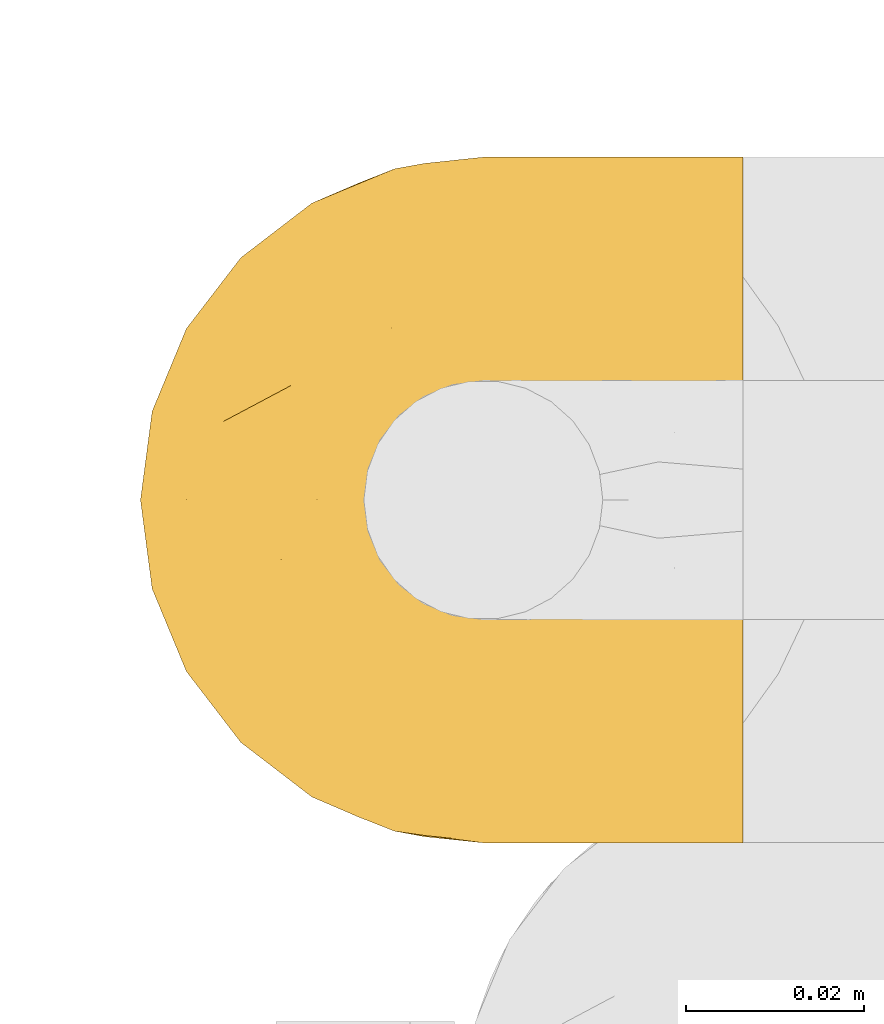
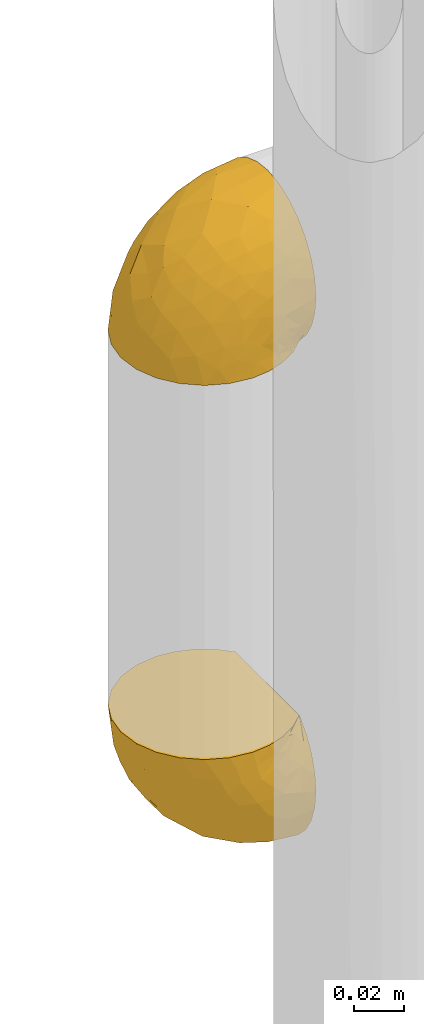
# One storey, part 114 of 827: 2 coverings.
"""IFC2X3 building model written with IfcOpenShell, lengths in millimetres."""

from ifc_helpers import new_model, entity, si_unit, converted_unit, derived_unit, direction, frame, origin, place, context, subcontext, project, spatial, faceted_brep, element, save


model = new_model("IFC2X3")

# Units and contexts
model_context = context("Model", 3, precision=0.01, world=origin(), true_north=direction((6.12303176911189e-17, 1.0)))
body_context = subcontext(model_context, "Body", "Model", "MODEL_VIEW")
ifc_project = project(units=[si_unit("LENGTHUNIT", "METRE", prefix="MILLI"), si_unit("AREAUNIT", "SQUARE_METRE"), si_unit("VOLUMEUNIT", "CUBIC_METRE"), converted_unit("PLANEANGLEUNIT", "DEGREE", entity("IfcRatioMeasure", 0.0174532925199433), si_unit("PLANEANGLEUNIT", "RADIAN"), dimensions=[0, 0, 0, 0, 0, 0, 0]), si_unit("MASSUNIT", "GRAM", prefix="KILO"), derived_unit("MASSDENSITYUNIT", [(si_unit("MASSUNIT", "GRAM", prefix="KILO"), 1), (si_unit("LENGTHUNIT", "METRE"), -3)]), derived_unit("MOMENTOFINERTIAUNIT", [(si_unit("LENGTHUNIT", "METRE"), 4)]), si_unit("TIMEUNIT", "SECOND"), si_unit("FREQUENCYUNIT", "HERTZ"), si_unit("THERMODYNAMICTEMPERATUREUNIT", "DEGREE_CELSIUS"), derived_unit("THERMALTRANSMITTANCEUNIT", [(si_unit("MASSUNIT", "GRAM", prefix="KILO"), 1), (si_unit("THERMODYNAMICTEMPERATUREUNIT", "KELVIN"), -1), (si_unit("TIMEUNIT", "SECOND"), -3)]), derived_unit("VOLUMETRICFLOWRATEUNIT", [(si_unit("LENGTHUNIT", "METRE"), 3), (si_unit("TIMEUNIT", "SECOND"), -1)]), derived_unit("MASSFLOWRATEUNIT", [(si_unit("MASSUNIT", "GRAM", prefix="KILO"), 1), (si_unit("TIMEUNIT", "SECOND"), -1)]), derived_unit("ROTATIONALFREQUENCYUNIT", [(si_unit("TIMEUNIT", "SECOND"), -1)]), si_unit("ELECTRICCURRENTUNIT", "AMPERE"), si_unit("ELECTRICVOLTAGEUNIT", "VOLT"), si_unit("POWERUNIT", "WATT"), si_unit("FORCEUNIT", "NEWTON", prefix="KILO"), si_unit("ILLUMINANCEUNIT", "LUX"), si_unit("LUMINOUSFLUXUNIT", "LUMEN"), si_unit("LUMINOUSINTENSITYUNIT", "CANDELA"), derived_unit("USERDEFINED", [(si_unit("MASSUNIT", "GRAM", prefix="KILO"), -1), (si_unit("LENGTHUNIT", "METRE"), -2), (si_unit("TIMEUNIT", "SECOND"), 3), (si_unit("LUMINOUSFLUXUNIT", "LUMEN"), 1)]), derived_unit("LINEARVELOCITYUNIT", [(si_unit("LENGTHUNIT", "METRE"), 1), (si_unit("TIMEUNIT", "SECOND"), -1)]), si_unit("PRESSUREUNIT", "PASCAL"), derived_unit("USERDEFINED", [(si_unit("LENGTHUNIT", "METRE"), -2), (si_unit("MASSUNIT", "GRAM", prefix="KILO"), 1), (si_unit("TIMEUNIT", "SECOND"), -2)]), derived_unit("LINEARFORCEUNIT", [(si_unit("MASSUNIT", "GRAM", prefix="KILO"), 1), (si_unit("LENGTHUNIT", "METRE"), 1), (si_unit("TIMEUNIT", "SECOND"), -2), (si_unit("LENGTHUNIT", "METRE"), -1)]), derived_unit("PLANARFORCEUNIT", [(si_unit("MASSUNIT", "GRAM", prefix="KILO"), 1), (si_unit("LENGTHUNIT", "METRE"), 1), (si_unit("TIMEUNIT", "SECOND"), -2), (si_unit("LENGTHUNIT", "METRE"), -2)])], contexts=[model_context])

# Site, building, storey
site_placement = place(None, origin())
site = spatial("IfcSite", under=ifc_project, at=site_placement, CompositionType="ELEMENT")
building_placement = place(site_placement, origin())
building = spatial("IfcBuilding", under=site, at=building_placement, CompositionType="ELEMENT")
storey_placement = place(building_placement, frame((0.0, 0.0, 28200.0)))
storey = spatial("IfcBuildingStorey", under=building, at=storey_placement, Name="08", CompositionType="ELEMENT", Elevation=28200.0)

# Coverings
covering_1_placement = place(storey_placement, frame((22641.02, 11905.95, 1018.27)))
element("IfcCovering", 1, at=covering_1_placement, inside=storey, Name=":ADSK_", ObjectType=":ADSK_", PredefinedType="INSULATION", context=body_context, shape_type="Brep", body=[
    faceted_brep([(69.15, 5.41, 23.36), (69.15, 9.99, 16.07), (69.15, 16.08, 9.98), (69.15, 23.37, 5.4), (69.15, 31.49, 2.56), (69.15, 40.05, 1.6), (69.15, 48.61, 2.56), (69.15, 56.73, 5.41), (69.15, 64.02, 9.99), (69.15, 70.11, 16.08), (69.15, 74.69, 23.37), (69.15, 77.53, 31.49), (69.15, 78.5, 40.05), (69.15, 77.63, 48.15), (69.15, 75.08, 55.88), (69.15, 70.97, 62.9), (69.15, 65.47, 68.89), (69.15, 63.27, 68.89), (69.15, 61.53, 68.89), (69.15, 59.57, 68.89), (69.15, 57.6, 68.89), (69.15, 55.63, 68.89), (69.15, 53.67, 68.89), (69.15, 51.7, 68.89), (69.15, 49.73, 68.89), (69.15, 47.54, 68.89), (69.15, 45.34, 68.89), (69.15, 43.15, 68.89), (69.15, 40.96, 68.89), (69.15, 38.76, 68.89), (69.15, 36.57, 68.89), (69.15, 34.37, 68.89), (69.15, 32.18, 68.89), (69.15, 29.98, 68.89), (69.15, 27.79, 68.89), (69.15, 25.6, 68.89), (69.15, 23.4, 68.89), (69.15, 21.21, 68.89), (69.15, 19.01, 68.89), (69.15, 16.82, 68.89), (69.15, 14.62, 68.89), (69.15, 9.12, 62.89), (69.15, 5.0, 55.86), (69.15, 2.46, 48.13), (69.15, 1.6, 40.05), (69.15, 2.56, 31.49), (68.89, 65.47, 69.15), (62.89, 70.97, 69.15), (55.87, 75.09, 69.15), (48.14, 77.63, 69.15), (40.05, 78.5, 69.15), (30.09, 77.19, 69.15), (20.82, 73.34, 69.15), (12.86, 67.23, 69.15), (6.75, 59.27, 69.15), (2.91, 50.0, 69.15), (1.6, 40.05, 69.15), (2.91, 30.09, 69.15), (6.75, 20.82, 69.15), (12.86, 12.86, 69.15), (20.82, 6.75, 69.15), (30.09, 2.91, 69.15), (40.05, 1.6, 69.15), (48.14, 2.46, 69.15), (55.87, 5.0, 69.15), (62.89, 9.12, 69.15), (68.89, 14.62, 69.15), (68.89, 16.82, 69.15), (68.89, 17.8, 69.15), (68.89, 19.39, 69.15), (68.89, 20.98, 69.15), (68.89, 22.57, 69.15), (68.89, 24.16, 69.15), (68.89, 25.75, 69.15), (68.89, 27.33, 69.15), (68.89, 28.92, 69.15), (68.89, 30.51, 69.15), (68.89, 32.1, 69.15), (68.89, 33.69, 69.15), (68.89, 35.28, 69.15), (68.89, 36.87, 69.15), (68.89, 38.46, 69.15), (68.89, 40.05, 69.15), (68.89, 41.63, 69.15), (68.89, 43.22, 69.15), (68.89, 44.81, 69.15), (68.89, 46.4, 69.15), (68.89, 47.99, 69.15), (68.89, 49.58, 69.15), (68.89, 51.17, 69.15), (68.89, 52.76, 69.15), (68.89, 54.72, 69.15), (68.89, 56.69, 69.15), (68.89, 58.88, 69.15), (68.89, 61.08, 69.15), (68.89, 63.27, 69.15), (68.97, 37.77, 68.96), (68.96, 36.07, 68.97), (68.97, 32.96, 68.97), (68.97, 31.36, 68.97), (68.98, 56.52, 68.95), (68.97, 54.96, 68.96), (68.96, 18.75, 68.98), (68.96, 58.07, 68.97), (68.96, 50.37, 68.97), (68.96, 23.36, 68.98), (68.96, 24.95, 68.97), (68.96, 42.43, 68.97), (69.0, 15.97, 68.94), (68.96, 51.96, 68.98), (68.96, 53.47, 68.98), (68.97, 48.63, 68.96), (68.96, 63.93, 68.97), (68.96, 40.93, 68.98), (68.96, 29.72, 68.98), (68.97, 62.4, 68.97), (68.97, 60.92, 68.96), (68.97, 17.31, 68.97), (68.96, 21.74, 68.97), (68.96, 34.56, 68.98), (68.97, 20.18, 68.96), (68.97, 14.62, 68.97), (69.02, 14.62, 68.94), (69.08, 14.62, 68.92), (68.97, 65.47, 68.97), (68.94, 65.47, 69.02), (68.92, 65.47, 69.08), (68.96, 59.5, 68.98), (68.96, 47.1, 68.97), (68.95, 45.61, 68.98), (68.96, 28.18, 68.97), (68.92, 14.62, 69.08), (68.94, 14.62, 69.02), (68.98, 26.61, 68.96), (69.08, 65.47, 68.92), (69.02, 65.47, 68.94), (68.96, 39.32, 68.97), (68.97, 44.12, 68.96), (61.33, 72.26, 67.02), (53.1, 76.57, 63.33), (63.33, 71.77, 64.61), (55.53, 77.9, 51.4), (63.33, 76.56, 53.1), (54.6, 78.5, 43.94), (41.99, 78.5, 61.87), (57.07, 75.52, 61.54), (57.95, 76.13, 57.95), (51.56, 77.81, 56.12), (41.58, 78.5, 63.4), (61.7, 72.4, 65.41), (65.0, 71.77, 63.04), (67.02, 72.25, 61.33), (61.87, 78.5, 41.99), (49.27, 78.5, 49.27), (43.94, 78.5, 54.6), (61.21, 75.75, 56.6), (63.4, 78.5, 41.58), (33.11, 50.46, 13.72), (52.82, 52.75, 5.82), (43.3, 40.05, 6.74), (33.73, 77.7, 58.82), (36.52, 77.66, 51.58), (24.87, 71.02, 42.09), (14.17, 63.45, 46.12), (18.43, 70.55, 55.56), (28.67, 75.57, 52.38), (26.0, 75.57, 61.54), (49.25, 72.61, 23.76), (59.72, 72.61, 20.5), (55.1, 67.24, 14.64), (44.72, 77.74, 41.77), (34.15, 57.43, 16.28), (5.25, 47.19, 49.4), (6.75, 54.76, 52.34), (55.54, 40.05, 4.3), (10.47, 63.45, 58.67), (25.49, 60.1, 25.26), (35.53, 63.72, 20.17), (48.22, 76.83, 34.7), (58.71, 76.34, 28.67), (57.42, 60.51, 8.62), (34.84, 72.59, 33.37), (36.87, 76.05, 41.35), (45.01, 66.15, 17.15), (44.4, 60.51, 12.68), (23.96, 51.88, 21.47), (11.2, 55.34, 41.11), (10.56, 48.67, 37.53), (16.81, 53.89, 30.64), (17.38, 46.73, 26.66), (21.38, 40.05, 21.38), (32.34, 40.05, 14.06), (4.3, 40.05, 55.54), (20.65, 63.95, 35.17), (29.66, 67.24, 29.04), (39.6, 69.62, 24.34), (42.55, 73.6, 29.33), (6.74, 40.05, 43.3), (14.06, 40.05, 32.34), (26.84, 4.52, 57.75), (5.28, 32.72, 49.41), (18.52, 27.18, 27.85), (33.13, 29.63, 13.7), (55.1, 12.86, 14.63), (57.43, 19.59, 8.61), (20.72, 9.54, 48.85), (11.46, 16.64, 54.13), (17.69, 17.48, 37.84), (49.26, 7.49, 23.75), (59.73, 7.49, 20.49), (58.71, 3.75, 28.66), (29.72, 20.75, 20.83), (35.35, 2.33, 55.15), (43.94, 1.6, 54.6), (41.99, 1.6, 61.87), (63.4, 1.6, 41.58), (4.93, 26.94, 57.58), (17.46, 9.54, 59.91), (10.94, 31.21, 36.94), (8.92, 25.33, 45.72), (52.83, 27.35, 5.82), (29.34, 8.17, 37.91), (30.26, 4.3, 50.18), (44.4, 19.59, 12.67), (39.06, 2.23, 49.29), (43.06, 2.45, 42.64), (54.6, 1.6, 43.94), (49.27, 1.6, 49.27), (42.69, 12.86, 19.45), (48.2, 3.27, 34.7), (61.87, 1.6, 41.99), (33.44, 2.29, 62.29), (29.67, 12.86, 29.01), (38.5, 6.89, 31.47), (23.35, 12.43, 37.18), (34.97, 4.1, 43.45), (53.1, 3.53, 63.33), (59.68, 6.88, 67.23), (62.19, 8.16, 66.07), (64.11, 9.02, 65.22), (57.97, 5.0, 61.99), (57.95, 3.96, 57.95), (63.33, 3.52, 53.09), (51.77, 2.4, 56.84), (67.02, 7.83, 61.33), (64.98, 8.32, 63.06), (55.53, 2.19, 51.41), (61.22, 4.34, 56.61)], [[[0, 1, 2, 3, 4, 5, 6, 7, 8, 9, 10, 11, 12, 13, 14, 15, 16, 17, 18, 19, 20, 21, 22, 23, 24, 25, 26, 27, 28, 29, 30, 31, 32, 33, 34, 35, 36, 37, 38, 39, 40, 41, 42, 43, 44, 45]], [[46, 47, 48, 49, 50, 51, 52, 53, 54, 55, 56, 57, 58, 59, 60, 61, 62, 63, 64, 65, 66, 67, 68, 69, 70, 71, 72, 73, 74, 75, 76, 77, 78, 79, 80, 81, 82, 83, 84, 85, 86, 87, 88, 89, 90, 91, 92, 93, 94, 95]], [[96, 97, 30]], [[98, 77, 99]], [[100, 101, 21]], [[69, 68, 102]], [[20, 19, 103]], [[24, 23, 104]], [[20, 103, 100]], [[72, 105, 106]], [[84, 83, 107]], [[89, 88, 104]], [[108, 67, 66]], [[109, 110, 90]], [[111, 25, 24]], [[112, 17, 16]], [[82, 113, 83]], [[109, 23, 22]], [[114, 76, 75]], [[105, 36, 106]], [[104, 111, 24]], [[18, 115, 116]], [[97, 96, 80]], [[67, 108, 117]], [[105, 71, 118]], [[31, 97, 119]], [[102, 120, 69]], [[108, 121, 122, 123, 40]], [[112, 95, 115]], [[17, 115, 18]], [[94, 116, 115]], [[117, 68, 67]], [[38, 117, 39]], [[112, 124, 125, 126, 46]], [[17, 112, 115]], [[70, 120, 118]], [[39, 117, 108]], [[120, 38, 37]], [[120, 37, 118]], [[120, 70, 69]], [[116, 94, 127]], [[128, 86, 129]], [[117, 38, 102]], [[74, 130, 75]], [[99, 33, 32]], [[115, 95, 94]], [[39, 108, 40]], [[108, 66, 131, 132, 121]], [[105, 72, 71]], [[118, 37, 36]], [[71, 70, 118]], [[35, 106, 36]], [[36, 105, 118]], [[35, 133, 106]], [[74, 73, 133]], [[106, 133, 73]], [[99, 114, 33]], [[133, 35, 34]], [[73, 72, 106]], [[95, 112, 46]], [[112, 16, 134, 135, 124]], [[130, 114, 75]], [[99, 76, 114]], [[114, 130, 33]], [[34, 33, 130]], [[78, 77, 98]], [[98, 119, 78]], [[130, 133, 34]], [[133, 130, 74]], [[79, 97, 80]], [[98, 99, 32]], [[98, 32, 31]], [[77, 76, 99]], [[97, 79, 119]], [[136, 96, 29]], [[30, 97, 31]], [[136, 29, 28]], [[81, 80, 96]], [[29, 96, 30]], [[31, 119, 98]], [[119, 79, 78]], [[96, 136, 81]], [[82, 81, 136]], [[113, 107, 83]], [[84, 107, 137]], [[107, 27, 137]], [[113, 28, 107]], [[27, 107, 28]], [[85, 84, 137]], [[137, 27, 26]], [[113, 136, 28]], [[136, 113, 82]], [[109, 89, 104]], [[86, 85, 129]], [[89, 109, 90]], [[111, 87, 128]], [[26, 129, 137]], [[88, 111, 104]], [[25, 111, 128]], [[22, 110, 109]], [[23, 109, 104]], [[110, 91, 90]], [[100, 92, 101]], [[110, 22, 101]], [[91, 110, 101]], [[116, 19, 18]], [[111, 88, 87]], [[127, 103, 19]], [[25, 128, 26]], [[86, 128, 87]], [[128, 129, 26]], [[137, 129, 85]], [[120, 102, 38]], [[117, 102, 68]], [[91, 101, 92]], [[21, 101, 22]], [[93, 92, 103]], [[100, 21, 20]], [[100, 103, 92]], [[127, 93, 103]], [[93, 127, 94]], [[116, 127, 19]], [[126, 138, 47]], [[48, 138, 139]], [[140, 125, 124]], [[141, 142, 143]], [[144, 49, 139]], [[145, 140, 146]], [[48, 139, 49]], [[139, 145, 147]], [[49, 144, 148, 50]], [[126, 125, 149]], [[14, 13, 142]], [[150, 146, 140]], [[149, 140, 145]], [[151, 150, 135]], [[151, 14, 142]], [[16, 15, 134]], [[13, 152, 142]], [[124, 150, 140]], [[141, 143, 153]], [[14, 151, 15]], [[15, 151, 134]], [[47, 46, 126]], [[139, 154, 144]], [[138, 48, 47]], [[125, 140, 149]], [[135, 134, 151]], [[146, 155, 141]], [[145, 146, 147]], [[149, 139, 138]], [[147, 153, 154]], [[147, 146, 141]], [[139, 147, 154]], [[139, 149, 145]], [[149, 138, 126]], [[147, 141, 153]], [[146, 150, 155]], [[151, 155, 150]], [[142, 141, 155]], [[13, 12, 156, 152]], [[152, 143, 142]], [[151, 142, 155]], [[150, 124, 135]], [[157, 158, 159]], [[160, 154, 161]], [[162, 163, 164]], [[165, 166, 160]], [[167, 168, 169]], [[153, 170, 161]], [[156, 12, 11]], [[158, 157, 171]], [[172, 55, 173]], [[158, 6, 174]], [[175, 54, 53]], [[52, 166, 164]], [[52, 164, 53]], [[54, 175, 173]], [[166, 52, 51]], [[176, 177, 171]], [[178, 143, 179]], [[156, 11, 179]], [[8, 7, 180]], [[169, 9, 8]], [[179, 143, 152, 156]], [[179, 11, 10]], [[168, 179, 10]], [[181, 162, 182]], [[179, 167, 178]], [[183, 184, 177]], [[183, 169, 184]], [[176, 171, 185]], [[172, 186, 187]], [[158, 7, 6]], [[159, 158, 174]], [[184, 180, 158]], [[54, 173, 55]], [[180, 169, 8]], [[188, 189, 187]], [[9, 168, 10]], [[186, 188, 187]], [[190, 157, 159, 191]], [[55, 172, 192]], [[176, 193, 194]], [[161, 170, 182]], [[162, 164, 165]], [[175, 164, 163]], [[51, 50, 148]], [[167, 195, 196]], [[178, 182, 170]], [[6, 5, 174]], [[158, 180, 7]], [[169, 180, 184]], [[169, 168, 9]], [[179, 168, 167]], [[182, 162, 165]], [[162, 194, 193]], [[161, 165, 160]], [[195, 181, 196]], [[192, 172, 197]], [[192, 56, 55]], [[189, 190, 198]], [[198, 197, 187]], [[172, 187, 197]], [[185, 189, 188]], [[198, 187, 189]], [[186, 172, 173]], [[173, 163, 186]], [[193, 186, 163]], [[176, 185, 188]], [[185, 157, 190]], [[188, 186, 193]], [[177, 176, 194]], [[188, 193, 176]], [[162, 193, 163]], [[195, 177, 194]], [[171, 177, 184]], [[181, 195, 194]], [[183, 167, 169]], [[162, 181, 194]], [[196, 182, 178]], [[158, 171, 184]], [[171, 157, 185]], [[177, 195, 183]], [[167, 183, 195]], [[182, 196, 181]], [[178, 170, 143]], [[178, 167, 196]], [[164, 175, 53]], [[173, 175, 163]], [[160, 51, 148]], [[164, 166, 165]], [[51, 160, 166]], [[160, 148, 144, 154]], [[153, 161, 154]], [[182, 165, 161]], [[190, 189, 185]], [[143, 170, 153]], [[60, 199, 61]], [[197, 200, 192]], [[201, 190, 202]], [[200, 57, 192]], [[203, 204, 2]], [[205, 206, 207]], [[208, 209, 210]], [[211, 207, 201]], [[212, 213, 214]], [[45, 215, 210]], [[216, 206, 58]], [[45, 44, 215]], [[59, 217, 60]], [[60, 217, 199]], [[0, 45, 210]], [[218, 201, 219]], [[202, 159, 220]], [[205, 221, 222]], [[223, 204, 203]], [[1, 203, 2]], [[57, 200, 216]], [[220, 3, 204]], [[220, 174, 4]], [[1, 0, 209]], [[212, 224, 213]], [[225, 226, 227]], [[228, 223, 203]], [[208, 210, 229]], [[210, 226, 229]], [[3, 220, 4]], [[58, 206, 59]], [[209, 203, 1]], [[202, 220, 223]], [[228, 203, 208]], [[202, 211, 201]], [[3, 2, 204]], [[202, 190, 191, 159]], [[210, 215, 230, 226]], [[199, 212, 231]], [[232, 233, 221]], [[233, 208, 229]], [[207, 206, 219]], [[217, 206, 205]], [[227, 224, 225]], [[233, 232, 228]], [[201, 207, 219]], [[234, 232, 221]], [[218, 219, 200]], [[202, 223, 211]], [[174, 220, 159]], [[174, 5, 4]], [[61, 231, 62]], [[220, 204, 223]], [[210, 209, 0]], [[203, 209, 208]], [[225, 233, 229]], [[224, 227, 213]], [[221, 233, 235]], [[57, 56, 192]], [[198, 218, 197]], [[200, 219, 216]], [[201, 198, 190]], [[197, 218, 200]], [[198, 201, 218]], [[206, 216, 219]], [[58, 57, 216]], [[231, 212, 214]], [[222, 212, 199]], [[228, 211, 223]], [[207, 211, 232]], [[62, 231, 214]], [[199, 231, 61]], [[233, 228, 208]], [[211, 228, 232]], [[222, 221, 235]], [[234, 205, 207]], [[206, 217, 59]], [[199, 217, 205]], [[205, 222, 199]], [[224, 222, 235]], [[222, 224, 212]], [[224, 235, 225]], [[233, 225, 235]], [[226, 225, 229]], [[205, 234, 221]], [[207, 232, 234]], [[63, 214, 236]], [[214, 213, 236]], [[214, 63, 62]], [[237, 236, 238]], [[238, 132, 131]], [[236, 237, 64]], [[239, 240, 241]], [[63, 236, 64]], [[131, 66, 65]], [[237, 131, 65]], [[242, 230, 43]], [[237, 65, 64]], [[239, 121, 132]], [[42, 242, 43]], [[241, 240, 243]], [[41, 123, 244]], [[43, 230, 215, 44]], [[244, 122, 245]], [[227, 246, 243]], [[241, 247, 245]], [[121, 239, 245]], [[41, 40, 123]], [[132, 238, 239]], [[244, 42, 41]], [[131, 237, 238]], [[240, 239, 238]], [[245, 239, 241]], [[247, 241, 246]], [[247, 244, 245]], [[238, 236, 240]], [[243, 236, 213]], [[236, 243, 240]], [[227, 226, 246]], [[243, 213, 227]], [[242, 246, 226]], [[243, 246, 241]], [[246, 242, 247]], [[244, 247, 242]], [[242, 226, 230]], [[42, 244, 242]], [[122, 244, 123]], [[122, 121, 245]]]),
])
covering_2_placement = place(storey_placement, frame((22641.02, 11905.95, 1267.62)))
element("IfcCovering", 2, at=covering_2_placement, inside=storey, Name=":ADSK_", ObjectType=":ADSK_", PredefinedType="INSULATION", context=body_context, shape_type="Brep", body=[
    faceted_brep([(69.15, 74.68, 47.38), (69.15, 70.1, 54.67), (69.15, 64.01, 60.76), (69.15, 56.72, 65.34), (69.15, 48.6, 68.18), (69.15, 40.05, 69.15), (69.15, 31.49, 68.18), (69.15, 23.36, 65.33), (69.15, 16.07, 60.75), (69.15, 9.98, 54.66), (69.15, 5.4, 47.37), (69.15, 2.56, 39.25), (69.15, 1.6, 30.7), (69.15, 2.46, 22.59), (69.15, 5.01, 14.86), (69.15, 9.13, 7.84), (69.15, 14.62, 1.85), (69.15, 16.82, 1.85), (69.15, 18.56, 1.85), (69.15, 20.52, 1.85), (69.15, 22.49, 1.85), (69.15, 24.46, 1.85), (69.15, 26.42, 1.85), (69.15, 28.39, 1.85), (69.15, 30.36, 1.85), (69.15, 32.55, 1.85), (69.15, 34.75, 1.85), (69.15, 36.94, 1.85), (69.15, 39.13, 1.85), (69.15, 41.33, 1.85), (69.15, 43.52, 1.85), (69.15, 45.72, 1.85), (69.15, 47.91, 1.85), (69.15, 50.11, 1.85), (69.15, 52.3, 1.85), (69.15, 54.49, 1.85), (69.15, 56.69, 1.85), (69.15, 58.88, 1.85), (69.15, 61.08, 1.85), (69.15, 63.27, 1.85), (69.15, 65.47, 1.85), (69.15, 70.97, 7.85), (69.15, 75.09, 14.88), (69.15, 77.64, 22.61), (69.15, 78.5, 30.7), (69.15, 77.53, 39.26), (68.89, 14.62, 1.6), (62.89, 9.12, 1.6), (55.87, 5.0, 1.6), (48.14, 2.46, 1.6), (40.05, 1.6, 1.6), (30.09, 2.91, 1.6), (20.82, 6.75, 1.6), (12.86, 12.86, 1.6), (6.75, 20.82, 1.6), (2.91, 30.09, 1.6), (1.6, 40.05, 1.6), (2.91, 50.0, 1.6), (6.75, 59.27, 1.6), (12.86, 67.23, 1.6), (20.82, 73.34, 1.6), (30.09, 77.19, 1.6), (40.05, 78.5, 1.6), (48.14, 77.63, 1.6), (55.87, 75.09, 1.6), (62.89, 70.97, 1.6), (68.89, 65.47, 1.6), (68.89, 63.27, 1.6), (68.89, 62.29, 1.6), (68.89, 60.7, 1.6), (68.89, 59.11, 1.6), (68.89, 57.52, 1.6), (68.89, 55.93, 1.6), (68.89, 54.34, 1.6), (68.89, 52.76, 1.6), (68.89, 51.17, 1.6), (68.89, 49.58, 1.6), (68.89, 47.99, 1.6), (68.89, 46.4, 1.6), (68.89, 44.81, 1.6), (68.89, 43.22, 1.6), (68.89, 41.63, 1.6), (68.89, 40.05, 1.6), (68.89, 38.46, 1.6), (68.89, 36.87, 1.6), (68.89, 35.28, 1.6), (68.89, 33.69, 1.6), (68.89, 32.1, 1.6), (68.89, 30.51, 1.6), (68.89, 28.92, 1.6), (68.89, 27.33, 1.6), (68.89, 25.37, 1.6), (68.89, 23.4, 1.6), (68.89, 21.21, 1.6), (68.89, 19.01, 1.6), (68.89, 16.82, 1.6), (68.97, 42.32, 1.78), (68.96, 44.02, 1.77), (68.97, 47.13, 1.78), (68.97, 48.74, 1.77), (68.98, 23.57, 1.79), (68.97, 25.13, 1.78), (68.96, 61.34, 1.76), (68.96, 22.02, 1.77), (68.96, 29.72, 1.77), (68.96, 56.73, 1.76), (68.96, 55.14, 1.77), (68.96, 37.66, 1.77), (69.0, 64.12, 1.8), (68.96, 28.13, 1.76), (68.96, 26.62, 1.77), (68.97, 31.46, 1.78), (68.96, 16.16, 1.77), (68.96, 39.16, 1.77), (68.96, 50.37, 1.76), (68.97, 17.69, 1.77), (68.97, 19.17, 1.78), (68.97, 62.78, 1.77), (68.96, 58.35, 1.77), (68.96, 45.53, 1.77), (68.97, 59.91, 1.78), (68.97, 65.47, 1.77), (69.02, 65.47, 1.8), (69.08, 65.47, 1.82), (68.97, 14.62, 1.77), (68.94, 14.62, 1.72), (68.92, 14.62, 1.66), (68.96, 20.59, 1.76), (68.96, 32.99, 1.77), (68.95, 34.48, 1.76), (68.96, 51.91, 1.77), (68.92, 65.47, 1.66), (68.94, 65.47, 1.72), (68.98, 53.48, 1.78), (69.08, 14.62, 1.82), (69.02, 14.62, 1.8), (68.96, 40.77, 1.77), (68.97, 35.97, 1.78), (61.33, 7.84, 3.72), (53.1, 3.53, 7.41), (63.33, 8.32, 6.13), (49.27, 1.6, 21.47), (55.53, 2.19, 19.34), (54.6, 1.6, 26.8), (41.99, 1.6, 8.87), (57.07, 4.57, 9.2), (57.95, 3.96, 12.79), (51.56, 2.28, 14.62), (41.58, 1.6, 7.34), (61.7, 7.69, 5.33), (63.33, 3.53, 17.64), (65.0, 8.32, 7.7), (67.02, 7.84, 9.41), (61.87, 1.6, 28.75), (43.94, 1.6, 16.15), (61.21, 4.34, 14.14), (63.4, 1.6, 29.16), (33.11, 29.63, 57.02), (52.82, 27.34, 64.92), (43.3, 40.05, 64.0), (33.73, 2.39, 11.92), (36.52, 2.43, 19.16), (24.87, 9.07, 28.65), (14.17, 16.64, 24.62), (18.43, 9.54, 15.19), (28.67, 4.52, 18.36), (26.0, 4.52, 9.2), (49.25, 7.49, 46.98), (59.72, 7.49, 50.24), (55.1, 12.85, 56.1), (44.72, 2.35, 28.97), (34.15, 22.66, 54.46), (5.25, 32.9, 21.34), (6.75, 25.33, 18.4), (55.54, 40.05, 66.44), (10.47, 16.64, 12.07), (25.49, 19.99, 45.49), (35.53, 16.37, 50.57), (48.22, 3.26, 36.04), (58.71, 3.75, 42.07), (57.42, 19.58, 62.12), (34.84, 7.5, 37.37), (36.87, 4.04, 29.39), (45.01, 13.94, 53.59), (44.4, 19.58, 58.06), (23.96, 28.21, 49.27), (11.2, 24.75, 29.63), (10.56, 31.42, 33.21), (16.81, 26.2, 40.1), (17.38, 33.36, 44.08), (21.38, 40.05, 49.36), (32.34, 40.05, 56.68), (4.3, 40.05, 15.2), (20.65, 16.14, 35.57), (29.66, 12.85, 41.7), (39.6, 10.47, 46.4), (42.55, 6.49, 41.41), (6.74, 40.05, 27.45), (14.06, 40.05, 38.4), (26.84, 75.57, 12.99), (5.28, 47.37, 21.33), (18.52, 52.91, 42.89), (33.13, 50.46, 57.04), (55.1, 67.23, 56.11), (57.43, 60.5, 62.13), (20.72, 70.55, 21.89), (11.46, 63.45, 16.62), (17.69, 62.61, 32.9), (49.26, 72.6, 46.99), (59.73, 72.6, 50.25), (58.71, 76.34, 42.08), (29.72, 59.34, 49.91), (35.35, 77.76, 15.6), (43.94, 78.5, 16.15), (41.99, 78.5, 8.87), (63.4, 78.5, 29.16), (4.93, 53.16, 13.16), (17.46, 70.55, 10.83), (10.94, 48.88, 33.8), (8.92, 54.76, 25.02), (52.83, 52.74, 64.92), (29.34, 71.93, 32.83), (30.26, 75.79, 20.56), (44.4, 60.5, 58.07), (39.06, 77.86, 21.46), (43.06, 77.64, 28.1), (54.6, 78.5, 26.8), (49.27, 78.5, 21.47), (42.69, 67.23, 51.29), (48.2, 76.82, 36.04), (61.87, 78.5, 28.75), (33.44, 77.8, 8.45), (29.67, 67.23, 41.73), (38.5, 73.2, 39.27), (23.35, 67.66, 33.56), (34.97, 75.99, 27.29), (53.1, 76.57, 7.41), (59.68, 73.21, 3.51), (62.19, 71.93, 4.68), (64.11, 71.07, 5.52), (57.97, 75.09, 8.75), (57.95, 76.13, 12.79), (63.33, 76.57, 17.65), (51.77, 77.69, 13.9), (67.02, 72.26, 9.42), (64.98, 71.77, 7.68), (55.53, 77.9, 19.33), (61.22, 75.75, 14.13)], [[[0, 1, 2, 3, 4, 5, 6, 7, 8, 9, 10, 11, 12, 13, 14, 15, 16, 17, 18, 19, 20, 21, 22, 23, 24, 25, 26, 27, 28, 29, 30, 31, 32, 33, 34, 35, 36, 37, 38, 39, 40, 41, 42, 43, 44, 45]], [[46, 47, 48, 49, 50, 51, 52, 53, 54, 55, 56, 57, 58, 59, 60, 61, 62, 63, 64, 65, 66, 67, 68, 69, 70, 71, 72, 73, 74, 75, 76, 77, 78, 79, 80, 81, 82, 83, 84, 85, 86, 87, 88, 89, 90, 91, 92, 93, 94, 95]], [[96, 97, 30]], [[98, 77, 99]], [[100, 101, 21]], [[69, 68, 102]], [[20, 19, 103]], [[24, 23, 104]], [[20, 103, 100]], [[72, 105, 106]], [[84, 83, 107]], [[89, 88, 104]], [[108, 67, 66]], [[109, 110, 90]], [[111, 25, 24]], [[112, 17, 16]], [[82, 113, 83]], [[109, 23, 22]], [[114, 76, 75]], [[105, 36, 106]], [[104, 111, 24]], [[18, 115, 116]], [[97, 96, 80]], [[67, 108, 117]], [[105, 71, 118]], [[31, 97, 119]], [[102, 120, 69]], [[108, 121, 122, 123, 40]], [[112, 95, 115]], [[17, 115, 18]], [[94, 116, 115]], [[117, 68, 67]], [[38, 117, 39]], [[112, 124, 125, 126, 46]], [[17, 112, 115]], [[70, 120, 118]], [[39, 117, 108]], [[120, 38, 37]], [[120, 37, 118]], [[120, 70, 69]], [[116, 94, 127]], [[128, 86, 129]], [[117, 38, 102]], [[74, 130, 75]], [[99, 33, 32]], [[115, 95, 94]], [[39, 108, 40]], [[108, 66, 131, 132, 121]], [[105, 72, 71]], [[118, 37, 36]], [[71, 70, 118]], [[35, 106, 36]], [[36, 105, 118]], [[35, 133, 106]], [[74, 73, 133]], [[106, 133, 73]], [[99, 114, 33]], [[133, 35, 34]], [[73, 72, 106]], [[95, 112, 46]], [[112, 16, 134, 135, 124]], [[130, 114, 75]], [[99, 76, 114]], [[114, 130, 33]], [[34, 33, 130]], [[78, 77, 98]], [[98, 119, 78]], [[130, 133, 34]], [[133, 130, 74]], [[79, 97, 80]], [[98, 99, 32]], [[98, 32, 31]], [[77, 76, 99]], [[97, 79, 119]], [[136, 96, 29]], [[30, 97, 31]], [[136, 29, 28]], [[81, 80, 96]], [[29, 96, 30]], [[31, 119, 98]], [[119, 79, 78]], [[96, 136, 81]], [[82, 81, 136]], [[113, 107, 83]], [[84, 107, 137]], [[107, 27, 137]], [[113, 28, 107]], [[27, 107, 28]], [[85, 84, 137]], [[137, 27, 26]], [[113, 136, 28]], [[136, 113, 82]], [[109, 89, 104]], [[86, 85, 129]], [[89, 109, 90]], [[111, 87, 128]], [[26, 129, 137]], [[88, 111, 104]], [[25, 111, 128]], [[22, 110, 109]], [[23, 109, 104]], [[110, 91, 90]], [[100, 92, 101]], [[110, 22, 101]], [[91, 110, 101]], [[116, 19, 18]], [[111, 88, 87]], [[127, 103, 19]], [[25, 128, 26]], [[86, 128, 87]], [[128, 129, 26]], [[137, 129, 85]], [[120, 102, 38]], [[117, 102, 68]], [[91, 101, 92]], [[21, 101, 22]], [[93, 92, 103]], [[100, 21, 20]], [[100, 103, 92]], [[127, 93, 103]], [[93, 127, 94]], [[116, 127, 19]], [[126, 138, 47]], [[48, 138, 139]], [[140, 125, 124]], [[141, 142, 143]], [[144, 49, 139]], [[145, 140, 146]], [[48, 139, 49]], [[139, 145, 147]], [[49, 144, 148, 50]], [[126, 125, 149]], [[14, 13, 150]], [[151, 146, 140]], [[149, 140, 145]], [[152, 151, 135]], [[152, 14, 150]], [[16, 15, 134]], [[13, 153, 150]], [[124, 151, 140]], [[141, 147, 142]], [[14, 152, 15]], [[15, 152, 134]], [[47, 46, 126]], [[139, 154, 144]], [[138, 48, 47]], [[125, 140, 149]], [[135, 134, 152]], [[146, 155, 142]], [[145, 146, 147]], [[149, 139, 138]], [[147, 141, 154]], [[147, 146, 142]], [[139, 147, 154]], [[139, 149, 145]], [[149, 138, 126]], [[155, 146, 151]], [[150, 143, 142]], [[152, 155, 151]], [[150, 142, 155]], [[13, 12, 156, 153]], [[153, 143, 150]], [[152, 150, 155]], [[151, 124, 135]], [[157, 158, 159]], [[160, 154, 161]], [[162, 163, 164]], [[165, 166, 160]], [[167, 168, 169]], [[141, 170, 161]], [[156, 12, 11]], [[158, 157, 171]], [[172, 55, 173]], [[158, 6, 174]], [[175, 54, 53]], [[52, 166, 164]], [[52, 164, 53]], [[54, 175, 173]], [[166, 52, 51]], [[176, 177, 171]], [[178, 143, 179]], [[156, 11, 179]], [[8, 7, 180]], [[169, 9, 8]], [[179, 143, 153, 156]], [[179, 11, 10]], [[168, 179, 10]], [[181, 162, 182]], [[179, 167, 178]], [[183, 184, 177]], [[183, 169, 184]], [[176, 171, 185]], [[172, 186, 187]], [[158, 7, 6]], [[159, 158, 174]], [[184, 180, 158]], [[54, 173, 55]], [[180, 169, 8]], [[188, 189, 187]], [[9, 168, 10]], [[186, 188, 187]], [[190, 157, 159, 191]], [[55, 172, 192]], [[176, 193, 194]], [[161, 170, 182]], [[162, 164, 165]], [[175, 164, 163]], [[51, 50, 148]], [[167, 195, 196]], [[178, 182, 170]], [[6, 5, 174]], [[158, 180, 7]], [[169, 180, 184]], [[169, 168, 9]], [[179, 168, 167]], [[182, 162, 165]], [[162, 194, 193]], [[161, 165, 160]], [[195, 181, 196]], [[192, 172, 197]], [[192, 56, 55]], [[189, 190, 198]], [[198, 197, 187]], [[172, 187, 197]], [[185, 189, 188]], [[198, 187, 189]], [[186, 172, 173]], [[173, 163, 186]], [[193, 186, 163]], [[176, 185, 188]], [[185, 157, 190]], [[188, 186, 193]], [[177, 176, 194]], [[188, 193, 176]], [[162, 193, 163]], [[195, 177, 194]], [[171, 177, 184]], [[181, 195, 194]], [[183, 167, 169]], [[162, 181, 194]], [[196, 182, 178]], [[158, 171, 184]], [[171, 157, 185]], [[177, 195, 183]], [[167, 183, 195]], [[182, 196, 181]], [[178, 170, 143]], [[178, 167, 196]], [[164, 175, 53]], [[173, 175, 163]], [[160, 51, 148]], [[164, 166, 165]], [[51, 160, 166]], [[160, 148, 144, 154]], [[141, 161, 154]], [[182, 165, 161]], [[190, 189, 185]], [[143, 170, 141]], [[60, 199, 61]], [[197, 200, 192]], [[201, 190, 202]], [[200, 57, 192]], [[203, 204, 2]], [[205, 206, 207]], [[208, 209, 210]], [[211, 207, 201]], [[212, 213, 214]], [[45, 215, 210]], [[216, 206, 58]], [[45, 44, 215]], [[59, 217, 60]], [[60, 217, 199]], [[0, 45, 210]], [[218, 201, 219]], [[202, 159, 220]], [[205, 221, 222]], [[223, 204, 203]], [[1, 203, 2]], [[57, 200, 216]], [[220, 3, 204]], [[220, 174, 4]], [[1, 0, 209]], [[212, 224, 213]], [[225, 226, 227]], [[228, 223, 203]], [[208, 210, 229]], [[210, 226, 229]], [[3, 220, 4]], [[58, 206, 59]], [[209, 203, 1]], [[202, 220, 223]], [[228, 203, 208]], [[202, 211, 201]], [[3, 2, 204]], [[202, 190, 191, 159]], [[210, 215, 230, 226]], [[199, 212, 231]], [[232, 233, 221]], [[233, 208, 229]], [[207, 206, 219]], [[217, 206, 205]], [[227, 224, 225]], [[233, 232, 228]], [[201, 207, 219]], [[234, 232, 221]], [[218, 219, 200]], [[202, 223, 211]], [[174, 220, 159]], [[174, 5, 4]], [[61, 231, 62]], [[220, 204, 223]], [[210, 209, 0]], [[203, 209, 208]], [[225, 233, 229]], [[224, 227, 213]], [[221, 233, 235]], [[57, 56, 192]], [[198, 218, 197]], [[200, 219, 216]], [[201, 198, 190]], [[197, 218, 200]], [[198, 201, 218]], [[206, 216, 219]], [[58, 57, 216]], [[231, 212, 214]], [[222, 212, 199]], [[228, 211, 223]], [[207, 211, 232]], [[62, 231, 214]], [[199, 231, 61]], [[233, 228, 208]], [[211, 228, 232]], [[222, 221, 235]], [[234, 205, 207]], [[206, 217, 59]], [[199, 217, 205]], [[205, 222, 199]], [[224, 222, 235]], [[222, 224, 212]], [[224, 235, 225]], [[233, 225, 235]], [[226, 225, 229]], [[205, 234, 221]], [[207, 232, 234]], [[63, 214, 236]], [[214, 213, 236]], [[214, 63, 62]], [[237, 236, 238]], [[238, 132, 131]], [[236, 237, 64]], [[239, 240, 241]], [[63, 236, 64]], [[131, 66, 65]], [[237, 131, 65]], [[242, 230, 43]], [[237, 65, 64]], [[239, 121, 132]], [[42, 242, 43]], [[241, 240, 243]], [[41, 123, 244]], [[43, 230, 215, 44]], [[244, 122, 245]], [[227, 246, 243]], [[245, 241, 247]], [[121, 239, 245]], [[41, 40, 123]], [[132, 238, 239]], [[244, 42, 41]], [[131, 237, 238]], [[240, 239, 238]], [[245, 239, 241]], [[247, 241, 246]], [[247, 244, 245]], [[238, 236, 240]], [[243, 236, 213]], [[236, 243, 240]], [[246, 241, 243]], [[243, 213, 227]], [[226, 242, 246]], [[227, 226, 246]], [[246, 242, 247]], [[244, 247, 242]], [[242, 226, 230]], [[42, 244, 242]], [[122, 244, 123]], [[122, 121, 245]]]),
])

save(model, "model.ifc")
